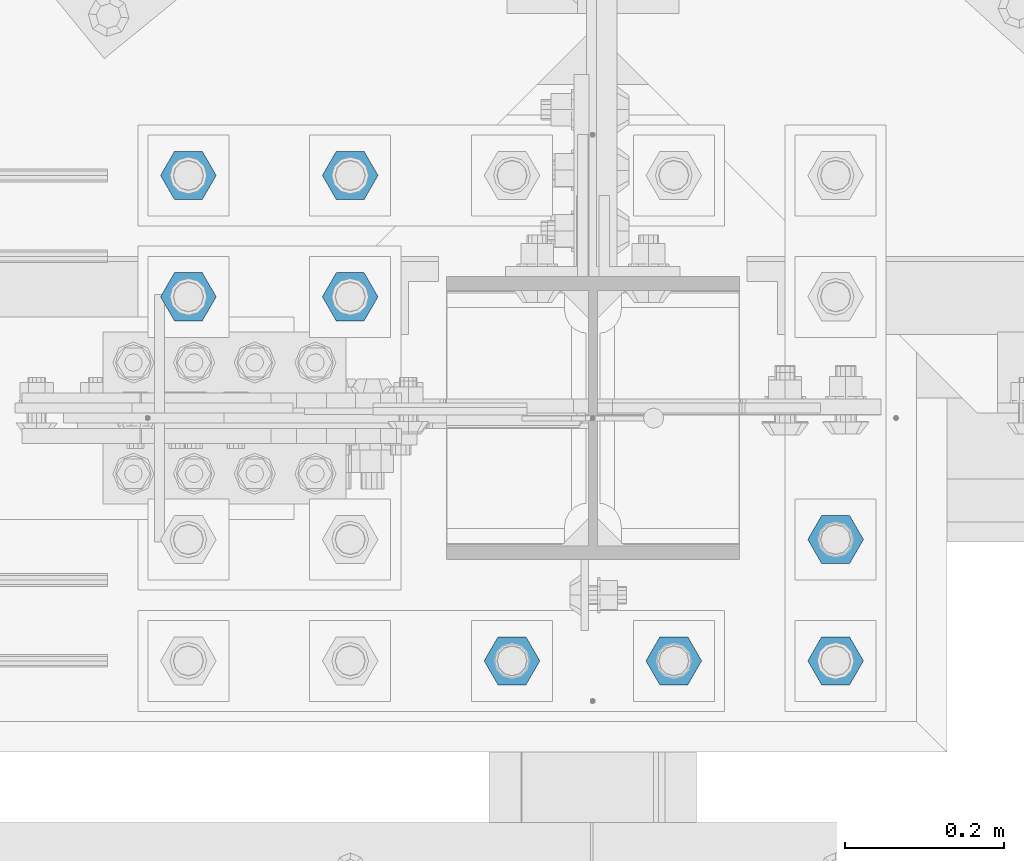
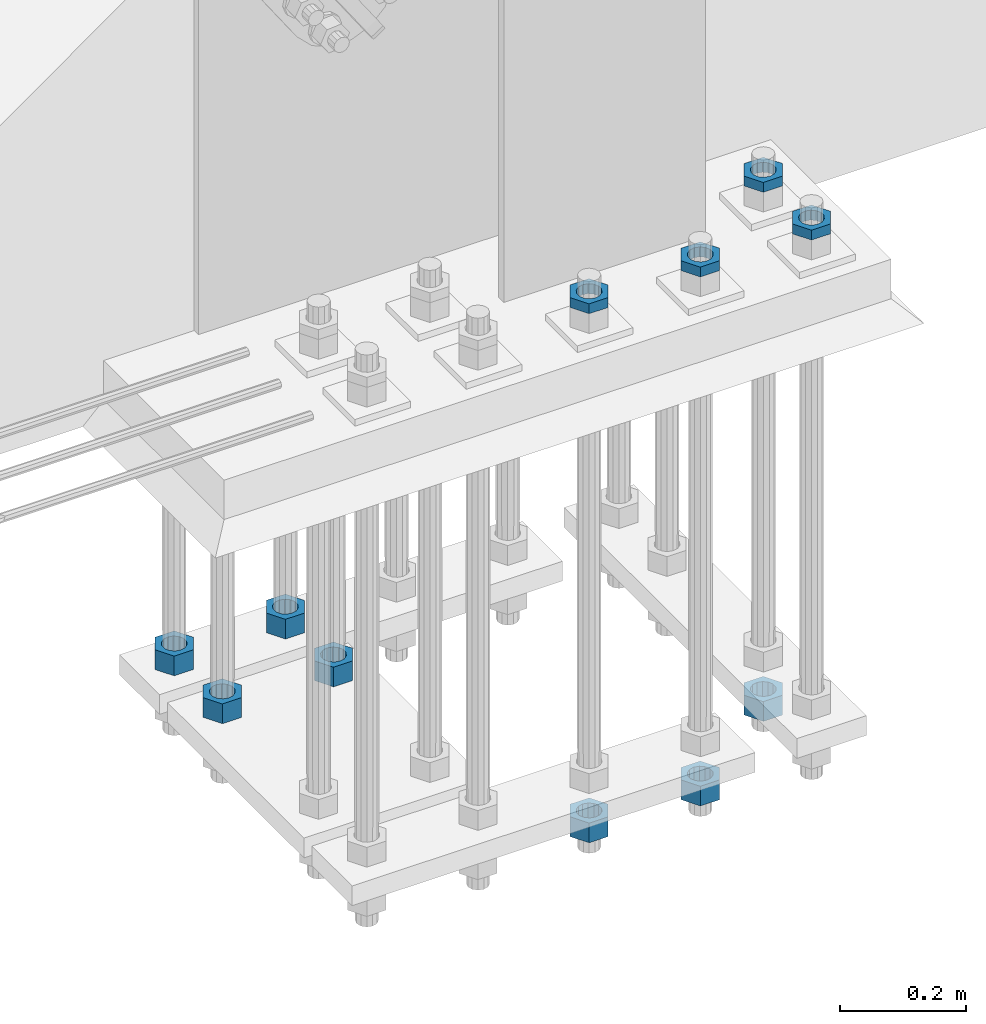
# One storey, part 2833 of 3843: 11 beams, 1 element without a shape of its own.
"""IFC2X3 building model written with IfcOpenShell, lengths in millimetres."""

from ifc_helpers import new_model, si_unit, frame, origin_with_axes, place, context, subcontext, project, spatial, faceted_brep, material, type_object, element, aggregate, save


model = new_model("IFC2X3")

# Units and contexts
model_context = context("Model", 3, precision=1e-05, world=origin_with_axes())
body_context = subcontext(model_context, "Body", "Model", "MODEL_VIEW")
ifc_project = project(units=[si_unit("LENGTHUNIT", "METRE", prefix="MILLI"), si_unit("AREAUNIT", "SQUARE_METRE"), si_unit("VOLUMEUNIT", "CUBIC_METRE"), si_unit("MASSUNIT", "GRAM", prefix="KILO"), si_unit("TIMEUNIT", "SECOND"), si_unit("PLANEANGLEUNIT", "RADIAN"), si_unit("SOLIDANGLEUNIT", "STERADIAN"), si_unit("THERMODYNAMICTEMPERATUREUNIT", "DEGREE_CELSIUS"), si_unit("LUMINOUSINTENSITYUNIT", "LUMEN")], contexts=[model_context])

# Site, building, storey
site_placement = place(None, origin_with_axes())
site = spatial("IfcSite", under=ifc_project, at=site_placement, CompositionType="ELEMENT")
building_placement = place(site_placement, origin_with_axes())
building = spatial("IfcBuilding", under=site, at=building_placement, Name="Undefined", CompositionType="ELEMENT")
storey_placement = place(building_placement, origin_with_axes())
storey = spatial("IfcBuildingStorey", under=building, at=storey_placement, Name="Undefined", CompositionType="ELEMENT", Elevation=0.0)

# Assembly, beams
assembly_placement = place(storey_placement, origin_with_axes())
assembly = element("IfcElementAssembly", 1, at=assembly_placement, inside=storey, Name="TEMPLATE", AssemblyPlace="NOTDEFINED", PredefinedType="RIGID_FRAME")
ifc_material = material(Name="STEEL/A572-50")
beam_type_1 = type_object("IfcBeamType", Name="1-1/2_HEAVY_HEX_NUT", PredefinedType="NOTDEFINED")
beam_1_placement = place(assembly_placement, frame((62331.6, 25920.7, 28841.7000015259), z_axis=(0.0, 1.0, 0.0), x_axis=(0.0, 0.0, -1.0)))
beam_1 = element("IfcBeam", 2, at=beam_1_placement, type_object=beam_type_1, material=ifc_material, Name="NUT", ObjectType="1-1/2_HEAVY_HEX_NUT", context=body_context, shape_type="Brep", body=[
    faceted_brep([(0.0, -34.9199981689453, 0.0), (0.0, -17.4599990844727, -30.25), (38.0999999999985, -17.4599990844727, -30.25), (38.0999999999985, -34.9199981689453, 0.0), (0.0, 17.4599990844727, -30.25), (38.0999999999985, 17.4599990844727, -30.25), (0.0, 34.9199981689453, 0.0), (38.0999999999985, 34.9199981689453, 0.0), (0.0, 17.4599990844727, 30.25), (38.0999999999985, 17.4599990844727, 30.25), (0.0, -17.4599990844727, 30.25), (38.0999999999985, -17.4599990844727, 30.25), (0.0, 0.0, 20.6399993896484), (0.0, 8.9553601105581, 18.5959968835959), (38.0999999999985, 8.9553601105581, 18.5959968835959), (38.0999999999985, 0.0, 20.6399993896484), (0.0, 16.1370013209525, 12.8688291298167), (38.0999999999985, 16.1370013209525, 12.8688291298167), (0.0, 20.1225115123816, 4.59283194104501), (38.0999999999985, 20.1225115123816, 4.59283194104501), (0.0, 20.1225115123816, -4.59283194104501), (38.0999999999985, 20.1225115123816, -4.59283194104501), (0.0, 16.1370013209525, -12.8688291298167), (38.0999999999985, 16.1370013209525, -12.8688291298167), (0.0, 8.9553601105581, -18.5959968835959), (38.0999999999985, 8.9553601105581, -18.5959968835959), (0.0, 0.0, -20.6399993896484), (38.0999999999985, 0.0, -20.6399993896484), (0.0, -8.9553601105581, -18.5959968835959), (38.0999999999985, -8.9553601105581, -18.5959968835959), (0.0, -16.1370013209525, -12.8688291298167), (38.0999999999985, -16.1370013209525, -12.8688291298167), (0.0, -20.1225115123816, -4.59283194104501), (38.0999999999985, -20.1225115123816, -4.59283194104501), (0.0, -20.1225115123816, 4.59283194104501), (38.0999999999985, -20.1225115123816, 4.59283194104501), (0.0, -16.1370013209525, 12.8688291298167), (38.0999999999985, -16.1370013209525, 12.8688291298167), (0.0, -8.9553601105581, 18.5959968835959), (38.0999999999985, -8.9553601105581, 18.5959968835959)], [[[0, 1, 2, 3]], [[1, 4, 5, 2]], [[4, 6, 7, 5]], [[6, 8, 9, 7]], [[8, 10, 11, 9]], [[10, 0, 3, 11]], [[12, 13, 14, 15]], [[13, 16, 17, 14]], [[16, 18, 19, 17]], [[18, 20, 21, 19]], [[20, 22, 23, 21]], [[22, 24, 25, 23]], [[24, 26, 27, 25]], [[26, 28, 29, 27]], [[28, 30, 31, 29]], [[30, 32, 33, 31]], [[32, 34, 35, 33]], [[34, 36, 37, 35]], [[36, 38, 39, 37]], [[38, 12, 15, 39]], [[5, 7, 9, 11, 3, 2], [17, 19, 21, 23, 25, 27, 29, 31, 33, 35, 37, 39, 15, 14]], [[10, 8, 6, 4, 1, 0], [38, 36, 34, 32, 30, 28, 26, 24, 22, 20, 18, 16, 13, 12]]]),
])
beam_2_placement = place(assembly_placement, frame((62128.4, 25920.7, 28841.7000015259), z_axis=(0.0, 1.0, 0.0), x_axis=(0.0, 0.0, -1.0)))
beam_2 = element("IfcBeam", 3, at=beam_2_placement, type_object=beam_type_1, material=ifc_material, Name="NUT", ObjectType="1-1/2_HEAVY_HEX_NUT", context=body_context, shape_type="Brep", body=[
    faceted_brep([(0.0, -34.9199981689453, 0.0), (0.0, -17.4599990844727, -30.25), (38.0999999999985, -17.4599990844727, -30.25), (38.0999999999985, -34.9199981689453, 0.0), (0.0, 17.4599990844727, -30.25), (38.0999999999985, 17.4599990844727, -30.25), (0.0, 34.9199981689453, 0.0), (38.0999999999985, 34.9199981689453, 0.0), (0.0, 17.4599990844727, 30.25), (38.0999999999985, 17.4599990844727, 30.25), (0.0, -17.4599990844727, 30.25), (38.0999999999985, -17.4599990844727, 30.25), (0.0, 0.0, 20.6399993896484), (0.0, 8.9553601105581, 18.5959968835959), (38.0999999999985, 8.9553601105581, 18.5959968835959), (38.0999999999985, 0.0, 20.6399993896484), (0.0, 16.1370013209525, 12.8688291298167), (38.0999999999985, 16.1370013209525, 12.8688291298167), (0.0, 20.1225115123816, 4.59283194104501), (38.0999999999985, 20.1225115123816, 4.59283194104501), (0.0, 20.1225115123816, -4.59283194104501), (38.0999999999985, 20.1225115123816, -4.59283194104501), (0.0, 16.1370013209525, -12.8688291298167), (38.0999999999985, 16.1370013209525, -12.8688291298167), (0.0, 8.9553601105581, -18.5959968835959), (38.0999999999985, 8.9553601105581, -18.5959968835959), (0.0, 0.0, -20.6399993896484), (38.0999999999985, 0.0, -20.6399993896484), (0.0, -8.9553601105581, -18.5959968835959), (38.0999999999985, -8.9553601105581, -18.5959968835959), (0.0, -16.1370013209525, -12.8688291298167), (38.0999999999985, -16.1370013209525, -12.8688291298167), (0.0, -20.1225115123816, -4.59283194104501), (38.0999999999985, -20.1225115123816, -4.59283194104501), (0.0, -20.1225115123816, 4.59283194104501), (38.0999999999985, -20.1225115123816, 4.59283194104501), (0.0, -16.1370013209525, 12.8688291298167), (38.0999999999985, -16.1370013209525, 12.8688291298167), (0.0, -8.9553601105581, 18.5959968835959), (38.0999999999985, -8.9553601105581, 18.5959968835959)], [[[0, 1, 2, 3]], [[1, 4, 5, 2]], [[4, 6, 7, 5]], [[6, 8, 9, 7]], [[8, 10, 11, 9]], [[10, 0, 3, 11]], [[12, 13, 14, 15]], [[13, 16, 17, 14]], [[16, 18, 19, 17]], [[18, 20, 21, 19]], [[20, 22, 23, 21]], [[22, 24, 25, 23]], [[24, 26, 27, 25]], [[26, 28, 29, 27]], [[28, 30, 31, 29]], [[30, 32, 33, 31]], [[32, 34, 35, 33]], [[34, 36, 37, 35]], [[36, 38, 39, 37]], [[38, 12, 15, 39]], [[5, 7, 9, 11, 3, 2], [17, 19, 21, 23, 25, 27, 29, 31, 33, 35, 37, 39, 15, 14]], [[10, 8, 6, 4, 1, 0], [38, 36, 34, 32, 30, 28, 26, 24, 22, 20, 18, 16, 13, 12]]]),
])
beam_3_placement = place(assembly_placement, frame((62128.4, 25768.3, 28841.7000015259), z_axis=(0.0, 1.0, 0.0), x_axis=(0.0, 0.0, -1.0)))
beam_3 = element("IfcBeam", 4, at=beam_3_placement, type_object=beam_type_1, material=ifc_material, Name="NUT", ObjectType="1-1/2_HEAVY_HEX_NUT", context=body_context, shape_type="Brep", body=[
    faceted_brep([(0.0, -34.9199981689453, 0.0), (0.0, -17.4599990844727, -30.25), (38.0999999999985, -17.4599990844727, -30.25), (38.0999999999985, -34.9199981689453, 0.0), (0.0, 17.4599990844727, -30.25), (38.0999999999985, 17.4599990844727, -30.25), (0.0, 34.9199981689453, 0.0), (38.0999999999985, 34.9199981689453, 0.0), (0.0, 17.4599990844727, 30.25), (38.0999999999985, 17.4599990844727, 30.25), (0.0, -17.4599990844727, 30.25), (38.0999999999985, -17.4599990844727, 30.25), (0.0, 0.0, 20.6399993896484), (0.0, 8.9553601105581, 18.5959968835959), (38.0999999999985, 8.9553601105581, 18.5959968835959), (38.0999999999985, 0.0, 20.6399993896484), (0.0, 16.1370013209525, 12.8688291298167), (38.0999999999985, 16.1370013209525, 12.8688291298167), (0.0, 20.1225115123816, 4.59283194104501), (38.0999999999985, 20.1225115123816, 4.59283194104501), (0.0, 20.1225115123816, -4.59283194104501), (38.0999999999985, 20.1225115123816, -4.59283194104501), (0.0, 16.1370013209525, -12.8688291298167), (38.0999999999985, 16.1370013209525, -12.8688291298167), (0.0, 8.9553601105581, -18.5959968835959), (38.0999999999985, 8.9553601105581, -18.5959968835959), (0.0, 0.0, -20.6399993896484), (38.0999999999985, 0.0, -20.6399993896484), (0.0, -8.9553601105581, -18.5959968835959), (38.0999999999985, -8.9553601105581, -18.5959968835959), (0.0, -16.1370013209525, -12.8688291298167), (38.0999999999985, -16.1370013209525, -12.8688291298167), (0.0, -20.1225115123816, -4.59283194104501), (38.0999999999985, -20.1225115123816, -4.59283194104501), (0.0, -20.1225115123816, 4.59283194104501), (38.0999999999985, -20.1225115123816, 4.59283194104501), (0.0, -16.1370013209525, 12.8688291298167), (38.0999999999985, -16.1370013209525, 12.8688291298167), (0.0, -8.9553601105581, 18.5959968835959), (38.0999999999985, -8.9553601105581, 18.5959968835959)], [[[0, 1, 2, 3]], [[1, 4, 5, 2]], [[4, 6, 7, 5]], [[6, 8, 9, 7]], [[8, 10, 11, 9]], [[10, 0, 3, 11]], [[12, 13, 14, 15]], [[13, 16, 17, 14]], [[16, 18, 19, 17]], [[18, 20, 21, 19]], [[20, 22, 23, 21]], [[22, 24, 25, 23]], [[24, 26, 27, 25]], [[26, 28, 29, 27]], [[28, 30, 31, 29]], [[30, 32, 33, 31]], [[32, 34, 35, 33]], [[34, 36, 37, 35]], [[36, 38, 39, 37]], [[38, 12, 15, 39]], [[5, 7, 9, 11, 3, 2], [17, 19, 21, 23, 25, 27, 29, 31, 33, 35, 37, 39, 15, 14]], [[10, 8, 6, 4, 1, 0], [38, 36, 34, 32, 30, 28, 26, 24, 22, 20, 18, 16, 13, 12]]]),
])
beam_4_placement = place(assembly_placement, frame((62331.6, 25768.3, 28841.7000015259), z_axis=(0.0, 1.0, 0.0), x_axis=(0.0, 0.0, -1.0)))
beam_4 = element("IfcBeam", 5, at=beam_4_placement, type_object=beam_type_1, material=ifc_material, Name="NUT", ObjectType="1-1/2_HEAVY_HEX_NUT", context=body_context, shape_type="Brep", body=[
    faceted_brep([(0.0, -34.9199981689453, 0.0), (0.0, -17.4599990844727, -30.25), (38.0999999999985, -17.4599990844727, -30.25), (38.0999999999985, -34.9199981689453, 0.0), (0.0, 17.4599990844727, -30.25), (38.0999999999985, 17.4599990844727, -30.25), (0.0, 34.9199981689453, 0.0), (38.0999999999985, 34.9199981689453, 0.0), (0.0, 17.4599990844727, 30.25), (38.0999999999985, 17.4599990844727, 30.25), (0.0, -17.4599990844727, 30.25), (38.0999999999985, -17.4599990844727, 30.25), (0.0, 0.0, 20.6399993896484), (0.0, 8.9553601105581, 18.5959968835959), (38.0999999999985, 8.9553601105581, 18.5959968835959), (38.0999999999985, 0.0, 20.6399993896484), (0.0, 16.1370013209525, 12.8688291298167), (38.0999999999985, 16.1370013209525, 12.8688291298167), (0.0, 20.1225115123816, 4.59283194104501), (38.0999999999985, 20.1225115123816, 4.59283194104501), (0.0, 20.1225115123816, -4.59283194104501), (38.0999999999985, 20.1225115123816, -4.59283194104501), (0.0, 16.1370013209525, -12.8688291298167), (38.0999999999985, 16.1370013209525, -12.8688291298167), (0.0, 8.9553601105581, -18.5959968835959), (38.0999999999985, 8.9553601105581, -18.5959968835959), (0.0, 0.0, -20.6399993896484), (38.0999999999985, 0.0, -20.6399993896484), (0.0, -8.9553601105581, -18.5959968835959), (38.0999999999985, -8.9553601105581, -18.5959968835959), (0.0, -16.1370013209525, -12.8688291298167), (38.0999999999985, -16.1370013209525, -12.8688291298167), (0.0, -20.1225115123816, -4.59283194104501), (38.0999999999985, -20.1225115123816, -4.59283194104501), (0.0, -20.1225115123816, 4.59283194104501), (38.0999999999985, -20.1225115123816, 4.59283194104501), (0.0, -16.1370013209525, 12.8688291298167), (38.0999999999985, -16.1370013209525, 12.8688291298167), (0.0, -8.9553601105581, 18.5959968835959), (38.0999999999985, -8.9553601105581, 18.5959968835959)], [[[0, 1, 2, 3]], [[1, 4, 5, 2]], [[4, 6, 7, 5]], [[6, 8, 9, 7]], [[8, 10, 11, 9]], [[10, 0, 3, 11]], [[12, 13, 14, 15]], [[13, 16, 17, 14]], [[16, 18, 19, 17]], [[18, 20, 21, 19]], [[20, 22, 23, 21]], [[22, 24, 25, 23]], [[24, 26, 27, 25]], [[26, 28, 29, 27]], [[28, 30, 31, 29]], [[30, 32, 33, 31]], [[32, 34, 35, 33]], [[34, 36, 37, 35]], [[36, 38, 39, 37]], [[38, 12, 15, 39]], [[5, 7, 9, 11, 3, 2], [17, 19, 21, 23, 25, 27, 29, 31, 33, 35, 37, 39, 15, 14]], [[10, 8, 6, 4, 1, 0], [38, 36, 34, 32, 30, 28, 26, 24, 22, 20, 18, 16, 13, 12]]]),
])
beam_5_placement = place(assembly_placement, frame((62738.0, 25311.1, 28746.4500015259), z_axis=(0.0, -1.0, 0.0), x_axis=(0.0, 0.0, -1.0)))
beam_5 = element("IfcBeam", 6, at=beam_5_placement, type_object=beam_type_1, material=ifc_material, Name="NUT", ObjectType="1-1/2_HEAVY_HEX_NUT", context=body_context, shape_type="Brep", body=[
    faceted_brep([(0.0, -34.9199981689453, 0.0), (0.0, -17.4599990844727, -30.25), (38.0999999999985, -17.4599990844727, -30.25), (38.0999999999985, -34.9199981689453, 0.0), (0.0, 17.4599990844727, -30.25), (38.0999999999985, 17.4599990844727, -30.25), (0.0, 34.9199981689453, 0.0), (38.0999999999985, 34.9199981689453, 0.0), (0.0, 17.4599990844727, 30.25), (38.0999999999985, 17.4599990844727, 30.25), (0.0, -17.4599990844727, 30.25), (38.0999999999985, -17.4599990844727, 30.25), (0.0, 0.0, 20.6399993896484), (0.0, 8.9553601105581, 18.5959968835959), (38.0999999999985, 8.9553601105581, 18.5959968835959), (38.0999999999985, 0.0, 20.6399993896484), (0.0, 16.1370013209525, 12.8688291298167), (38.0999999999985, 16.1370013209525, 12.8688291298167), (0.0, 20.1225115123816, 4.59283194104501), (38.0999999999985, 20.1225115123816, 4.59283194104501), (0.0, 20.1225115123816, -4.59283194104501), (38.0999999999985, 20.1225115123816, -4.59283194104501), (0.0, 16.1370013209525, -12.8688291298167), (38.0999999999985, 16.1370013209525, -12.8688291298167), (0.0, 8.9553601105581, -18.5959968835959), (38.0999999999985, 8.9553601105581, -18.5959968835959), (0.0, 0.0, -20.6399993896484), (38.0999999999985, 0.0, -20.6399993896484), (0.0, -8.9553601105581, -18.5959968835959), (38.0999999999985, -8.9553601105581, -18.5959968835959), (0.0, -16.1370013209525, -12.8688291298167), (38.0999999999985, -16.1370013209525, -12.8688291298167), (0.0, -20.1225115123816, -4.59283194104501), (38.0999999999985, -20.1225115123816, -4.59283194104501), (0.0, -20.1225115123816, 4.59283194104501), (38.0999999999985, -20.1225115123816, 4.59283194104501), (0.0, -16.1370013209525, 12.8688291298167), (38.0999999999985, -16.1370013209525, 12.8688291298167), (0.0, -8.9553601105581, 18.5959968835959), (38.0999999999985, -8.9553601105581, 18.5959968835959)], [[[0, 1, 2, 3]], [[1, 4, 5, 2]], [[4, 6, 7, 5]], [[6, 8, 9, 7]], [[8, 10, 11, 9]], [[10, 0, 3, 11]], [[12, 13, 14, 15]], [[13, 16, 17, 14]], [[16, 18, 19, 17]], [[18, 20, 21, 19]], [[20, 22, 23, 21]], [[22, 24, 25, 23]], [[24, 26, 27, 25]], [[26, 28, 29, 27]], [[28, 30, 31, 29]], [[30, 32, 33, 31]], [[32, 34, 35, 33]], [[34, 36, 37, 35]], [[36, 38, 39, 37]], [[38, 12, 15, 39]], [[5, 7, 9, 11, 3, 2], [17, 19, 21, 23, 25, 27, 29, 31, 33, 35, 37, 39, 15, 14]], [[10, 8, 6, 4, 1, 0], [38, 36, 34, 32, 30, 28, 26, 24, 22, 20, 18, 16, 13, 12]]]),
])
beam_6_placement = place(assembly_placement, frame((62534.8, 25311.1, 28746.4500015259), z_axis=(0.0, -1.0, 0.0), x_axis=(0.0, 0.0, -1.0)))
beam_6 = element("IfcBeam", 7, at=beam_6_placement, type_object=beam_type_1, material=ifc_material, Name="NUT", ObjectType="1-1/2_HEAVY_HEX_NUT", context=body_context, shape_type="Brep", body=[
    faceted_brep([(0.0, -34.9199981689453, 0.0), (0.0, -17.4599990844727, -30.25), (38.0999999999985, -17.4599990844727, -30.25), (38.0999999999985, -34.9199981689453, 0.0), (0.0, 17.4599990844727, -30.25), (38.0999999999985, 17.4599990844727, -30.25), (0.0, 34.9199981689453, 0.0), (38.0999999999985, 34.9199981689453, 0.0), (0.0, 17.4599990844727, 30.25), (38.0999999999985, 17.4599990844727, 30.25), (0.0, -17.4599990844727, 30.25), (38.0999999999985, -17.4599990844727, 30.25), (0.0, 0.0, 20.6399993896484), (0.0, 8.9553601105581, 18.5959968835959), (38.0999999999985, 8.9553601105581, 18.5959968835959), (38.0999999999985, 0.0, 20.6399993896484), (0.0, 16.1370013209525, 12.8688291298167), (38.0999999999985, 16.1370013209525, 12.8688291298167), (0.0, 20.1225115123816, 4.59283194104501), (38.0999999999985, 20.1225115123816, 4.59283194104501), (0.0, 20.1225115123816, -4.59283194104501), (38.0999999999985, 20.1225115123816, -4.59283194104501), (0.0, 16.1370013209525, -12.8688291298167), (38.0999999999985, 16.1370013209525, -12.8688291298167), (0.0, 8.9553601105581, -18.5959968835959), (38.0999999999985, 8.9553601105581, -18.5959968835959), (0.0, 0.0, -20.6399993896484), (38.0999999999985, 0.0, -20.6399993896484), (0.0, -8.9553601105581, -18.5959968835959), (38.0999999999985, -8.9553601105581, -18.5959968835959), (0.0, -16.1370013209525, -12.8688291298167), (38.0999999999985, -16.1370013209525, -12.8688291298167), (0.0, -20.1225115123816, -4.59283194104501), (38.0999999999985, -20.1225115123816, -4.59283194104501), (0.0, -20.1225115123816, 4.59283194104501), (38.0999999999985, -20.1225115123816, 4.59283194104501), (0.0, -16.1370013209525, 12.8688291298167), (38.0999999999985, -16.1370013209525, 12.8688291298167), (0.0, -8.9553601105581, 18.5959968835959), (38.0999999999985, -8.9553601105581, 18.5959968835959)], [[[0, 1, 2, 3]], [[1, 4, 5, 2]], [[4, 6, 7, 5]], [[6, 8, 9, 7]], [[8, 10, 11, 9]], [[10, 0, 3, 11]], [[12, 13, 14, 15]], [[13, 16, 17, 14]], [[16, 18, 19, 17]], [[18, 20, 21, 19]], [[20, 22, 23, 21]], [[22, 24, 25, 23]], [[24, 26, 27, 25]], [[26, 28, 29, 27]], [[28, 30, 31, 29]], [[30, 32, 33, 31]], [[32, 34, 35, 33]], [[34, 36, 37, 35]], [[36, 38, 39, 37]], [[38, 12, 15, 39]], [[5, 7, 9, 11, 3, 2], [17, 19, 21, 23, 25, 27, 29, 31, 33, 35, 37, 39, 15, 14]], [[10, 8, 6, 4, 1, 0], [38, 36, 34, 32, 30, 28, 26, 24, 22, 20, 18, 16, 13, 12]]]),
])
beam_7_placement = place(assembly_placement, frame((62941.2, 25463.5, 28746.4500015259), z_axis=(0.0, -1.0, 0.0), x_axis=(0.0, 0.0, -1.0)))
beam_7 = element("IfcBeam", 8, at=beam_7_placement, type_object=beam_type_1, material=ifc_material, Name="NUT", ObjectType="1-1/2_HEAVY_HEX_NUT", context=body_context, shape_type="Brep", body=[
    faceted_brep([(0.0, -34.9199981689453, 0.0), (0.0, -17.4599990844727, -30.25), (38.0999999999985, -17.4599990844727, -30.25), (38.0999999999985, -34.9199981689453, 0.0), (0.0, 17.4599990844727, -30.25), (38.0999999999985, 17.4599990844727, -30.25), (0.0, 34.9199981689453, 0.0), (38.0999999999985, 34.9199981689453, 0.0), (0.0, 17.4599990844727, 30.25), (38.0999999999985, 17.4599990844727, 30.25), (0.0, -17.4599990844727, 30.25), (38.0999999999985, -17.4599990844727, 30.25), (0.0, 0.0, 20.6399993896484), (0.0, 8.9553601105581, 18.5959968835959), (38.0999999999985, 8.9553601105581, 18.5959968835959), (38.0999999999985, 0.0, 20.6399993896484), (0.0, 16.1370013209525, 12.8688291298167), (38.0999999999985, 16.1370013209525, 12.8688291298167), (0.0, 20.1225115123816, 4.59283194104501), (38.0999999999985, 20.1225115123816, 4.59283194104501), (0.0, 20.1225115123816, -4.59283194104501), (38.0999999999985, 20.1225115123816, -4.59283194104501), (0.0, 16.1370013209525, -12.8688291298167), (38.0999999999985, 16.1370013209525, -12.8688291298167), (0.0, 8.9553601105581, -18.5959968835959), (38.0999999999985, 8.9553601105581, -18.5959968835959), (0.0, 0.0, -20.6399993896484), (38.0999999999985, 0.0, -20.6399993896484), (0.0, -8.9553601105581, -18.5959968835959), (38.0999999999985, -8.9553601105581, -18.5959968835959), (0.0, -16.1370013209525, -12.8688291298167), (38.0999999999985, -16.1370013209525, -12.8688291298167), (0.0, -20.1225115123816, -4.59283194104501), (38.0999999999985, -20.1225115123816, -4.59283194104501), (0.0, -20.1225115123816, 4.59283194104501), (38.0999999999985, -20.1225115123816, 4.59283194104501), (0.0, -16.1370013209525, 12.8688291298167), (38.0999999999985, -16.1370013209525, 12.8688291298167), (0.0, -8.9553601105581, 18.5959968835959), (38.0999999999985, -8.9553601105581, 18.5959968835959)], [[[0, 1, 2, 3]], [[1, 4, 5, 2]], [[4, 6, 7, 5]], [[6, 8, 9, 7]], [[8, 10, 11, 9]], [[10, 0, 3, 11]], [[12, 13, 14, 15]], [[13, 16, 17, 14]], [[16, 18, 19, 17]], [[18, 20, 21, 19]], [[20, 22, 23, 21]], [[22, 24, 25, 23]], [[24, 26, 27, 25]], [[26, 28, 29, 27]], [[28, 30, 31, 29]], [[30, 32, 33, 31]], [[32, 34, 35, 33]], [[34, 36, 37, 35]], [[36, 38, 39, 37]], [[38, 12, 15, 39]], [[5, 7, 9, 11, 3, 2], [17, 19, 21, 23, 25, 27, 29, 31, 33, 35, 37, 39, 15, 14]], [[10, 8, 6, 4, 1, 0], [38, 36, 34, 32, 30, 28, 26, 24, 22, 20, 18, 16, 13, 12]]]),
])
beam_type_2 = type_object("IfcBeamType", Name="1-1/2_HALF_NUT", PredefinedType="NOTDEFINED")
beam_8_placement = place(assembly_placement, frame((62941.2, 25311.1, 29749.75), z_axis=(0.0, -1.0, 0.0), x_axis=(0.0, 0.0, -1.0)))
beam_8 = element("IfcBeam", 9, at=beam_8_placement, type_object=beam_type_2, material=ifc_material, Name="NUT", ObjectType="1-1/2_HALF_NUT", context=body_context, shape_type="Brep", body=[
    faceted_brep([(0.0, -34.9199981689453, 0.0), (0.0, -17.4599990844727, -30.25), (19.0500000000029, -17.4599990844727, -30.25), (19.0500000000029, -34.9199981689453, 0.0), (0.0, 17.4599990844727, -30.25), (19.0500000000029, 17.4599990844727, -30.25), (0.0, 34.9199981689453, 0.0), (19.0500000000029, 34.9199981689453, 0.0), (0.0, 17.4599990844727, 30.25), (19.0500000000029, 17.4599990844727, 30.25), (0.0, -17.4599990844727, 30.25), (19.0500000000029, -17.4599990844727, 30.25), (0.0, 0.0, 20.6399993896484), (0.0, 8.9553601105581, 18.5959968835959), (19.0500000000029, 8.95536011056538, 18.5959968835959), (19.0500000000029, 0.0, 20.6399993896484), (0.0, 16.1370013209525, 12.8688291298167), (19.0500000000029, 16.1370013209489, 12.8688291298167), (0.0, 20.1225115123816, 4.59283194104501), (19.0500000000029, 20.1225115123852, 4.59283194104501), (0.0, 20.1225115123816, -4.59283194104501), (19.0500000000029, 20.1225115123852, -4.59283194104501), (0.0, 16.1370013209525, -12.8688291298167), (19.0500000000029, 16.1370013209489, -12.8688291298167), (0.0, 8.9553601105581, -18.5959968835959), (19.0500000000029, 8.95536011056538, -18.5959968835959), (0.0, 0.0, -20.6399993896484), (19.0500000000029, 0.0, -20.6399993896484), (0.0, -8.9553601105581, -18.5959968835959), (19.0500000000029, -8.95536011056538, -18.5959968835959), (0.0, -16.1370013209525, -12.8688291298167), (19.0500000000029, -16.1370013209489, -12.8688291298167), (0.0, -20.1225115123816, -4.59283194104501), (19.0500000000029, -20.1225115123852, -4.59283194104501), (0.0, -20.1225115123816, 4.59283194104501), (19.0500000000029, -20.1225115123852, 4.59283194104501), (0.0, -16.1370013209525, 12.8688291298167), (19.0500000000029, -16.1370013209489, 12.8688291298167), (0.0, -8.9553601105581, 18.5959968835959), (19.0500000000029, -8.95536011056538, 18.5959968835959)], [[[0, 1, 2, 3]], [[1, 4, 5, 2]], [[4, 6, 7, 5]], [[6, 8, 9, 7]], [[8, 10, 11, 9]], [[10, 0, 3, 11]], [[12, 13, 14, 15]], [[13, 16, 17, 14]], [[16, 18, 19, 17]], [[18, 20, 21, 19]], [[20, 22, 23, 21]], [[22, 24, 25, 23]], [[24, 26, 27, 25]], [[26, 28, 29, 27]], [[28, 30, 31, 29]], [[30, 32, 33, 31]], [[32, 34, 35, 33]], [[34, 36, 37, 35]], [[36, 38, 39, 37]], [[38, 12, 15, 39]], [[5, 7, 9, 11, 3, 2], [17, 19, 21, 23, 25, 27, 29, 31, 33, 35, 37, 39, 15, 14]], [[10, 8, 6, 4, 1, 0], [38, 36, 34, 32, 30, 28, 26, 24, 22, 20, 18, 16, 13, 12]]]),
])
beam_9_placement = place(assembly_placement, frame((62738.0, 25311.1, 29749.75), z_axis=(0.0, -1.0, 0.0), x_axis=(0.0, 0.0, -1.0)))
beam_9 = element("IfcBeam", 10, at=beam_9_placement, type_object=beam_type_2, material=ifc_material, Name="NUT", ObjectType="1-1/2_HALF_NUT", context=body_context, shape_type="Brep", body=[
    faceted_brep([(0.0, -34.9199981689453, 0.0), (0.0, -17.4599990844727, -30.25), (19.0500000000029, -17.4599990844727, -30.25), (19.0500000000029, -34.9199981689453, 0.0), (0.0, 17.4599990844727, -30.25), (19.0500000000029, 17.4599990844727, -30.25), (0.0, 34.9199981689453, 0.0), (19.0500000000029, 34.9199981689453, 0.0), (0.0, 17.4599990844727, 30.25), (19.0500000000029, 17.4599990844727, 30.25), (0.0, -17.4599990844727, 30.25), (19.0500000000029, -17.4599990844727, 30.25), (0.0, 0.0, 20.6399993896484), (0.0, 8.9553601105581, 18.5959968835959), (19.0500000000029, 8.95536011056538, 18.5959968835959), (19.0500000000029, 0.0, 20.6399993896484), (0.0, 16.1370013209525, 12.8688291298167), (19.0500000000029, 16.1370013209489, 12.8688291298167), (0.0, 20.1225115123816, 4.59283194104501), (19.0500000000029, 20.1225115123852, 4.59283194104501), (0.0, 20.1225115123816, -4.59283194104501), (19.0500000000029, 20.1225115123852, -4.59283194104501), (0.0, 16.1370013209525, -12.8688291298167), (19.0500000000029, 16.1370013209489, -12.8688291298167), (0.0, 8.9553601105581, -18.5959968835959), (19.0500000000029, 8.95536011056538, -18.5959968835959), (0.0, 0.0, -20.6399993896484), (19.0500000000029, 0.0, -20.6399993896484), (0.0, -8.9553601105581, -18.5959968835959), (19.0500000000029, -8.95536011056538, -18.5959968835959), (0.0, -16.1370013209525, -12.8688291298167), (19.0500000000029, -16.1370013209489, -12.8688291298167), (0.0, -20.1225115123816, -4.59283194104501), (19.0500000000029, -20.1225115123852, -4.59283194104501), (0.0, -20.1225115123816, 4.59283194104501), (19.0500000000029, -20.1225115123852, 4.59283194104501), (0.0, -16.1370013209525, 12.8688291298167), (19.0500000000029, -16.1370013209489, 12.8688291298167), (0.0, -8.9553601105581, 18.5959968835959), (19.0500000000029, -8.95536011056538, 18.5959968835959)], [[[0, 1, 2, 3]], [[1, 4, 5, 2]], [[4, 6, 7, 5]], [[6, 8, 9, 7]], [[8, 10, 11, 9]], [[10, 0, 3, 11]], [[12, 13, 14, 15]], [[13, 16, 17, 14]], [[16, 18, 19, 17]], [[18, 20, 21, 19]], [[20, 22, 23, 21]], [[22, 24, 25, 23]], [[24, 26, 27, 25]], [[26, 28, 29, 27]], [[28, 30, 31, 29]], [[30, 32, 33, 31]], [[32, 34, 35, 33]], [[34, 36, 37, 35]], [[36, 38, 39, 37]], [[38, 12, 15, 39]], [[5, 7, 9, 11, 3, 2], [17, 19, 21, 23, 25, 27, 29, 31, 33, 35, 37, 39, 15, 14]], [[10, 8, 6, 4, 1, 0], [38, 36, 34, 32, 30, 28, 26, 24, 22, 20, 18, 16, 13, 12]]]),
])
beam_10_placement = place(assembly_placement, frame((62534.8, 25311.1, 29749.75), z_axis=(0.0, -1.0, 0.0), x_axis=(0.0, 0.0, -1.0)))
beam_10 = element("IfcBeam", 11, at=beam_10_placement, type_object=beam_type_2, material=ifc_material, Name="NUT", ObjectType="1-1/2_HALF_NUT", context=body_context, shape_type="Brep", body=[
    faceted_brep([(0.0, -34.9199981689453, 0.0), (0.0, -17.4599990844727, -30.25), (19.0500000000029, -17.4599990844727, -30.25), (19.0500000000029, -34.9199981689453, 0.0), (0.0, 17.4599990844727, -30.25), (19.0500000000029, 17.4599990844727, -30.25), (0.0, 34.9199981689453, 0.0), (19.0500000000029, 34.9199981689453, 0.0), (0.0, 17.4599990844727, 30.25), (19.0500000000029, 17.4599990844727, 30.25), (0.0, -17.4599990844727, 30.25), (19.0500000000029, -17.4599990844727, 30.25), (0.0, 0.0, 20.6399993896484), (0.0, 8.9553601105581, 18.5959968835959), (19.0500000000029, 8.95536011056538, 18.5959968835959), (19.0500000000029, 0.0, 20.6399993896484), (0.0, 16.1370013209525, 12.8688291298167), (19.0500000000029, 16.1370013209489, 12.8688291298167), (0.0, 20.1225115123816, 4.59283194104501), (19.0500000000029, 20.1225115123852, 4.59283194104501), (0.0, 20.1225115123816, -4.59283194104501), (19.0500000000029, 20.1225115123852, -4.59283194104501), (0.0, 16.1370013209525, -12.8688291298167), (19.0500000000029, 16.1370013209489, -12.8688291298167), (0.0, 8.9553601105581, -18.5959968835959), (19.0500000000029, 8.95536011056538, -18.5959968835959), (0.0, 0.0, -20.6399993896484), (19.0500000000029, 0.0, -20.6399993896484), (0.0, -8.9553601105581, -18.5959968835959), (19.0500000000029, -8.95536011056538, -18.5959968835959), (0.0, -16.1370013209525, -12.8688291298167), (19.0500000000029, -16.1370013209489, -12.8688291298167), (0.0, -20.1225115123816, -4.59283194104501), (19.0500000000029, -20.1225115123852, -4.59283194104501), (0.0, -20.1225115123816, 4.59283194104501), (19.0500000000029, -20.1225115123852, 4.59283194104501), (0.0, -16.1370013209525, 12.8688291298167), (19.0500000000029, -16.1370013209489, 12.8688291298167), (0.0, -8.9553601105581, 18.5959968835959), (19.0500000000029, -8.95536011056538, 18.5959968835959)], [[[0, 1, 2, 3]], [[1, 4, 5, 2]], [[4, 6, 7, 5]], [[6, 8, 9, 7]], [[8, 10, 11, 9]], [[10, 0, 3, 11]], [[12, 13, 14, 15]], [[13, 16, 17, 14]], [[16, 18, 19, 17]], [[18, 20, 21, 19]], [[20, 22, 23, 21]], [[22, 24, 25, 23]], [[24, 26, 27, 25]], [[26, 28, 29, 27]], [[28, 30, 31, 29]], [[30, 32, 33, 31]], [[32, 34, 35, 33]], [[34, 36, 37, 35]], [[36, 38, 39, 37]], [[38, 12, 15, 39]], [[5, 7, 9, 11, 3, 2], [17, 19, 21, 23, 25, 27, 29, 31, 33, 35, 37, 39, 15, 14]], [[10, 8, 6, 4, 1, 0], [38, 36, 34, 32, 30, 28, 26, 24, 22, 20, 18, 16, 13, 12]]]),
])
beam_11_placement = place(assembly_placement, frame((62941.2, 25463.5, 29749.75), z_axis=(0.0, -1.0, 0.0), x_axis=(0.0, 0.0, -1.0)))
beam_11 = element("IfcBeam", 12, at=beam_11_placement, type_object=beam_type_2, material=ifc_material, Name="NUT", ObjectType="1-1/2_HALF_NUT", context=body_context, shape_type="Brep", body=[
    faceted_brep([(0.0, -34.9199981689453, 0.0), (0.0, -17.4599990844727, -30.25), (19.0500000000029, -17.4599990844727, -30.25), (19.0500000000029, -34.9199981689453, 0.0), (0.0, 17.4599990844727, -30.25), (19.0500000000029, 17.4599990844727, -30.25), (0.0, 34.9199981689453, 0.0), (19.0500000000029, 34.9199981689453, 0.0), (0.0, 17.4599990844727, 30.25), (19.0500000000029, 17.4599990844727, 30.25), (0.0, -17.4599990844727, 30.25), (19.0500000000029, -17.4599990844727, 30.25), (0.0, 0.0, 20.6399993896484), (0.0, 8.9553601105581, 18.5959968835959), (19.0500000000029, 8.95536011056538, 18.5959968835959), (19.0500000000029, 0.0, 20.6399993896484), (0.0, 16.1370013209525, 12.8688291298167), (19.0500000000029, 16.1370013209489, 12.8688291298167), (0.0, 20.1225115123816, 4.59283194104501), (19.0500000000029, 20.1225115123852, 4.59283194104501), (0.0, 20.1225115123816, -4.59283194104501), (19.0500000000029, 20.1225115123852, -4.59283194104501), (0.0, 16.1370013209525, -12.8688291298167), (19.0500000000029, 16.1370013209489, -12.8688291298167), (0.0, 8.9553601105581, -18.5959968835959), (19.0500000000029, 8.95536011056538, -18.5959968835959), (0.0, 0.0, -20.6399993896484), (19.0500000000029, 0.0, -20.6399993896484), (0.0, -8.9553601105581, -18.5959968835959), (19.0500000000029, -8.95536011056538, -18.5959968835959), (0.0, -16.1370013209525, -12.8688291298167), (19.0500000000029, -16.1370013209489, -12.8688291298167), (0.0, -20.1225115123816, -4.59283194104501), (19.0500000000029, -20.1225115123852, -4.59283194104501), (0.0, -20.1225115123816, 4.59283194104501), (19.0500000000029, -20.1225115123852, 4.59283194104501), (0.0, -16.1370013209525, 12.8688291298167), (19.0500000000029, -16.1370013209489, 12.8688291298167), (0.0, -8.9553601105581, 18.5959968835959), (19.0500000000029, -8.95536011056538, 18.5959968835959)], [[[0, 1, 2, 3]], [[1, 4, 5, 2]], [[4, 6, 7, 5]], [[6, 8, 9, 7]], [[8, 10, 11, 9]], [[10, 0, 3, 11]], [[12, 13, 14, 15]], [[13, 16, 17, 14]], [[16, 18, 19, 17]], [[18, 20, 21, 19]], [[20, 22, 23, 21]], [[22, 24, 25, 23]], [[24, 26, 27, 25]], [[26, 28, 29, 27]], [[28, 30, 31, 29]], [[30, 32, 33, 31]], [[32, 34, 35, 33]], [[34, 36, 37, 35]], [[36, 38, 39, 37]], [[38, 12, 15, 39]], [[5, 7, 9, 11, 3, 2], [17, 19, 21, 23, 25, 27, 29, 31, 33, 35, 37, 39, 15, 14]], [[10, 8, 6, 4, 1, 0], [38, 36, 34, 32, 30, 28, 26, 24, 22, 20, 18, 16, 13, 12]]]),
])
aggregate(assembly, [beam_1, beam_2, beam_3, beam_4, beam_5, beam_6, beam_7, beam_8, beam_9, beam_10, beam_11])

save(model, "model.ifc")
